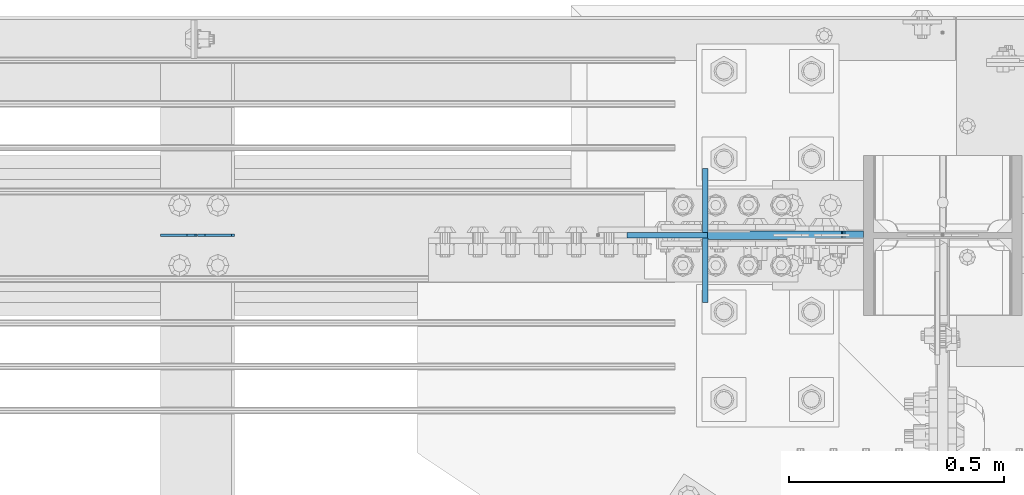
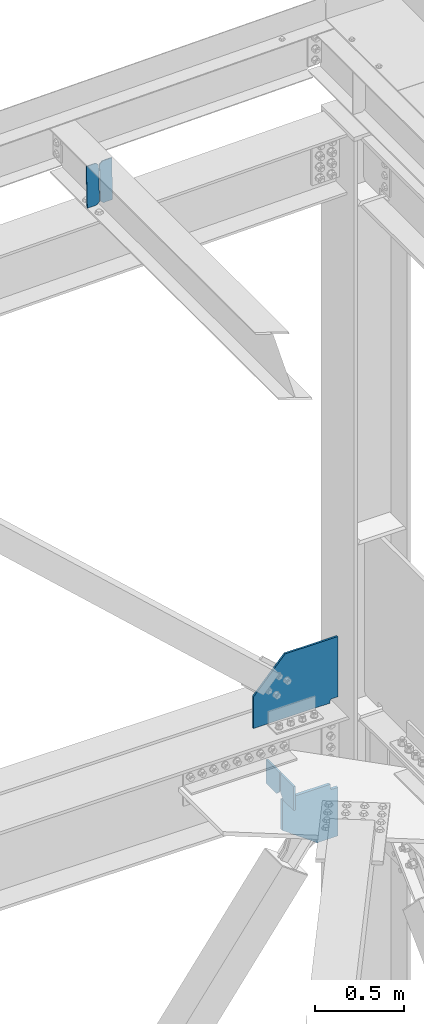
# One storey, part 3650 of 3843: 6 plates, 3 elements without a shape of their own.
"""IFC2X3 building model written with IfcOpenShell, lengths in millimetres."""

from ifc_helpers import new_model, si_unit, frame, origin_with_axes, place, context, subcontext, project, spatial, faceted_brep, material, type_object, element, aggregate, save


model = new_model("IFC2X3")

# Units and contexts
model_context = context("Model", 3, precision=1e-05, world=origin_with_axes())
body_context = subcontext(model_context, "Body", "Model", "MODEL_VIEW")
ifc_project = project(units=[si_unit("LENGTHUNIT", "METRE", prefix="MILLI"), si_unit("AREAUNIT", "SQUARE_METRE"), si_unit("VOLUMEUNIT", "CUBIC_METRE"), si_unit("MASSUNIT", "GRAM", prefix="KILO"), si_unit("TIMEUNIT", "SECOND"), si_unit("PLANEANGLEUNIT", "RADIAN"), si_unit("SOLIDANGLEUNIT", "STERADIAN"), si_unit("THERMODYNAMICTEMPERATUREUNIT", "DEGREE_CELSIUS"), si_unit("LUMINOUSINTENSITYUNIT", "LUMEN")], contexts=[model_context])

# Site, building, storey
site_placement = place(None, origin_with_axes())
site = spatial("IfcSite", under=ifc_project, at=site_placement, CompositionType="ELEMENT")
building_placement = place(site_placement, origin_with_axes())
building = spatial("IfcBuilding", under=site, at=building_placement, Name="Undefined", CompositionType="ELEMENT")
storey_placement = place(building_placement, origin_with_axes())
storey = spatial("IfcBuildingStorey", under=building, at=storey_placement, Name="Undefined", CompositionType="ELEMENT", Elevation=0.0)

# Assembly, plates
assembly_1_placement = place(storey_placement, origin_with_axes())
assembly_1 = element("IfcElementAssembly", 1, at=assembly_1_placement, inside=storey, Name="BEAM", AssemblyPlace="NOTDEFINED", PredefinedType="RIGID_FRAME")
ifc_material = material(Name="STEEL/A572-50")
plate_type_1 = type_object("IfcPlateType", PredefinedType="NOTDEFINED")
plate_1_placement = place(assembly_1_placement, frame((84003.8964784351, 104559.100000002, 46432.9140160753), z_axis=(-0.0211520980073474, 0.0, 0.999776269347241), x_axis=(-0.999776270257024, 0.0, -0.0211520550054595)))
plate_1 = element("IfcPlate", 2, at=plate_1_placement, type_object=plate_type_1, material=ifc_material, Name="STIFFENER", context=body_context, shape_type="Brep", body=[
    faceted_brep([(0.0, -3.17499999999927, 0.0), (6.83940015733242e-10, -3.17499999996653, 288.924999998613), (6.54836185276508e-10, 3.17500000001746, 288.924999998591), (0.0, 3.17499999999927, 0.0), (61.9125003828667, -3.17499999997744, 288.924999998599), (61.9125003828522, 3.17500000002838, 288.924999998584), (79.3750000013097, -3.17499999997744, 271.462500380039), (79.375000001266, 3.17500000002838, 271.462500380017), (79.375000000713, -3.17499999999927, 17.4624996185448), (79.3750000006694, 3.17500000000291, 17.462499618523), (61.9125003821828, -3.17499999999563, -1.45519152283669e-11), (61.9125003821682, 3.17500000000655, -2.91038304567337e-11)], [[[0, 1, 2, 3]], [[1, 4, 5, 2]], [[4, 6, 7, 5]], [[6, 8, 9, 7]], [[8, 10, 11, 9]], [[10, 0, 3, 11]], [[5, 7, 9, 11, 3, 2]], [[10, 8, 6, 4, 1, 0]]]),
])
plate_2_placement = place(assembly_1_placement, frame((83918.1906577449, 104559.100000002, 46431.1007524736), z_axis=(-0.0211520980073474, 0.0, 0.999776269347241), x_axis=(-0.999776270257024, 0.0, -0.0211520550054595)))
plate_2 = element("IfcPlate", 3, at=plate_2_placement, type_object=plate_type_1, material=ifc_material, Name="STIFFENER", context=body_context, shape_type="Brep", body=[
    faceted_brep([(5.82076609134674e-11, -3.17499999999927, 17.4624996185667), (6.25732354819775e-10, -3.17499999997744, 271.462500380054), (5.82076609134674e-10, 3.17500000002474, 271.462500380039), (0.0, 3.17500000000655, 17.4624996185521), (17.462499619156, -3.17499999997744, 288.924999998606), (17.4624996191269, 3.17500000002474, 288.924999998591), (79.3750000013242, -3.17500000025029, 288.924999998591), (79.3750000013097, 3.1749999997337, 288.92499999857), (79.3750000006548, -3.17500000026484, -2.18278728425503e-11), (79.3750000006403, 3.17499999969732, -2.91038304567337e-11), (17.4624996184866, -3.17500000000291, 7.27595761418343e-12), (17.462499618443, 3.17500000000291, -7.27595761418343e-12)], [[[0, 1, 2, 3]], [[1, 4, 5, 2]], [[4, 6, 7, 5]], [[6, 8, 9, 7]], [[8, 10, 11, 9]], [[10, 0, 3, 11]], [[5, 7, 9, 11, 3, 2]], [[10, 8, 6, 4, 1, 0]]]),
])
aggregate(assembly_1, [plate_1, plate_2])

assembly_2_placement = place(storey_placement, origin_with_axes())
assembly_2 = element("IfcElementAssembly", 4, at=assembly_2_placement, inside=storey, Name="COLUMN", AssemblyPlace="NOTDEFINED", PredefinedType="RIGID_FRAME")
plate_type_2 = type_object("IfcPlateType", PredefinedType="NOTDEFINED")
plate_3_placement = place(assembly_2_placement, frame((85464.650000013, 104559.100000322, 42481.5000000008), z_axis=(0.0, 0.0, 1.0), x_axis=(-1.0, 0.0, 0.0)))
plate_3 = element("IfcPlate", 5, at=plate_3_placement, type_object=plate_type_2, material=ifc_material, Name="PLATE", context=body_context, shape_type="Brep", body=[
    faceted_brep([(0.0, -6.35000000000582, 25.3999999992011), (0.0, 6.35000000000582, 25.3999999992011), (38.1000002037326, 6.35000000000582, 25.3999999992011), (38.1000002037326, -6.35000000000582, 25.3999999992011), (42.9600797217718, 6.35000000000582, 24.4332700766099), (42.9600797217718, -6.35000000000582, 24.4332700766099), (47.0802561899327, 6.35000000000582, 21.680256176136), (47.0802561899327, -6.35000000000582, 21.680256176136), (49.8332700904139, 6.35000000000582, 17.5600797079824), (49.8332700904139, -6.35000000000582, 17.5600797079824), (50.8000000129978, -6.35000000000582, 12.700000189936), (50.8000000129978, 6.35000000000582, 12.700000189936), (50.8000000129978, 6.35000000000582, 0.0), (50.8000000129978, -6.35000000000582, 0.0), (0.0, -6.35000000000582, 440.392120302837), (342.865167624404, -6.35000000000582, 440.392120302837), (342.865167624404, 6.35000000000582, 440.392120302837), (0.0, 6.35000000000582, 440.392120302837), (548.874980480497, -6.35000000000582, 215.752415426345), (548.874980480497, 6.35000000000582, 215.752415426345), (548.874980480497, -6.35000000000582, 0.0), (548.874980480497, 6.35000000000582, 0.0)], [[[0, 1, 2, 3]], [[3, 2, 4, 5]], [[5, 4, 6, 7]], [[7, 6, 8, 9]], [[10, 11, 12, 13]], [[9, 8, 11, 10]], [[14, 15, 16, 17]], [[15, 18, 19, 16]], [[18, 20, 21, 19]], [[21, 20, 13, 12]], [[6, 4, 2, 1, 17, 16, 19, 21, 12, 11, 8]], [[14, 17, 1, 0]], [[20, 18, 15, 14, 0, 3, 5, 7, 9, 10, 13]]]),
])
plate_type_3 = type_object("IfcPlateType", PredefinedType="NOTDEFINED")
plate_4_placement = place(assembly_2_placement, frame((85102.543580626, 104559.1, 41925.875), z_axis=(0.0, 0.0, -1.0), x_axis=(1.0, 0.0, 0.0)))
plate_4 = element("IfcPlate", 6, at=plate_4_placement, type_object=plate_type_3, material=ifc_material, Name="CB", context=body_context, shape_type="Brep", body=[
    faceted_brep([(311.306419374014, -9.52499999999418, 0.0), (311.306419374014, 9.52499999999418, 0.0), (311.306419374014, 9.52499999999418, 25.4000001907334), (311.306419374014, -9.52499999999418, 25.4000001907334), (312.273149296598, 9.52499999999418, 30.2600797087798), (312.273149296598, -9.52499999999418, 30.2600797087798), (315.026163197079, 9.52499999999418, 34.3802561769335), (315.026163197079, -9.52499999999418, 34.3802561769335), (319.14633966524, 9.52499999999418, 37.1332700774074), (319.14633966524, -9.52499999999418, 37.1332700774074), (324.006419183279, 9.52499999999418, 38.0999999999985), (324.006419183279, -9.52499999999418, 38.0999999999985), (362.106419374017, -9.52499999999418, 38.0999999999985), (362.106419374017, 9.52499999999418, 38.0999999999985), (0.0, -9.52500000000146, 0.0), (0.0, -9.52499999999418, 207.925841260338), (0.0, 9.52499999999418, 207.925841260338), (0.0, 9.52500000000146, 0.0), (226.006727863452, -9.52499999999418, 372.074926991598), (226.006727863452, 9.52499999999418, 372.074926991598), (362.106419374017, -9.52499999999418, 372.074926991598), (362.106419374017, 9.52499999999418, 372.074926991598)], [[[0, 1, 2, 3]], [[3, 2, 4, 5]], [[5, 4, 6, 7]], [[7, 6, 8, 9]], [[9, 8, 10, 11]], [[12, 11, 10, 13]], [[14, 15, 16, 17]], [[15, 18, 19, 16]], [[18, 20, 21, 19]], [[21, 20, 12, 13]], [[8, 6, 4, 2, 1, 17, 16, 19, 21, 13, 10]], [[14, 17, 1, 0]], [[20, 18, 15, 14, 0, 3, 5, 7, 9, 11, 12]]]),
])
aggregate(assembly_2, [plate_3, plate_4])

assembly_3_placement = place(storey_placement, origin_with_axes())
assembly_3 = element("IfcElementAssembly", 7, at=assembly_3_placement, inside=storey, Name="BEAM", AssemblyPlace="NOTDEFINED", PredefinedType="RIGID_FRAME")
plate_type_4 = type_object("IfcPlateType", PredefinedType="NOTDEFINED")
plate_5_placement = place(assembly_3_placement, frame((85097.781080626, 104552.75, 42110.025), z_axis=(0.0, 0.0, -1.0), x_axis=(0.0, -1.0, 0.0)))
plate_5 = element("IfcPlate", 8, at=plate_5_placement, type_object=plate_type_4, material=ifc_material, Name="PLATE", context=body_context, shape_type="Brep", body=[
    faceted_brep([(0.0, -6.3499999046162, 0.0), (0.0, -6.35000000000582, 131.762499999997), (0.0, 6.35000000000582, 131.762499999997), (7.27595761418343e-12, 6.3499999046162, 0.0), (31.75, -6.35000000000582, 163.512499999997), (31.75, 6.35000000000582, 163.512499999997), (149.224999999991, -6.35000000000582, 163.512499999997), (149.224999999991, 6.35000000000582, 163.512499999997), (149.224999999991, -6.35000000000582, 0.0), (149.224999999991, 6.35000000000582, 0.0)], [[[0, 1, 2, 3]], [[1, 4, 5, 2]], [[4, 6, 7, 5]], [[6, 8, 9, 7]], [[8, 0, 3, 9]], [[5, 7, 9, 3, 2]], [[8, 6, 4, 1, 0]]]),
])
plate_6_placement = place(assembly_3_placement, frame((85097.781080626, 104565.45, 42110.025), z_axis=(0.0, 0.0, -1.0), x_axis=(0.0, 1.0, 0.0)))
plate_6 = element("IfcPlate", 9, at=plate_6_placement, type_object=plate_type_4, material=ifc_material, Name="PLATE", context=body_context, shape_type="Brep", body=[
    faceted_brep([(0.0, -6.3499999046162, 0.0), (0.0, -6.35000000000582, 131.762499999997), (0.0, 6.35000000000582, 131.762499999997), (7.27595761418343e-12, 6.3499999046162, 0.0), (31.75, -6.35000000000582, 163.512499999997), (31.75, 6.35000000000582, 163.512499999997), (149.224999999991, -6.35000000000582, 163.512499999997), (149.224999999991, 6.35000000000582, 163.512499999997), (149.224999999991, -6.35000000000582, 0.0), (149.224999999991, 6.35000000000582, 0.0)], [[[0, 1, 2, 3]], [[1, 4, 5, 2]], [[4, 6, 7, 5]], [[6, 8, 9, 7]], [[8, 0, 3, 9]], [[5, 7, 9, 3, 2]], [[8, 6, 4, 1, 0]]]),
])
aggregate(assembly_3, [plate_5, plate_6])

save(model, "model.ifc")
